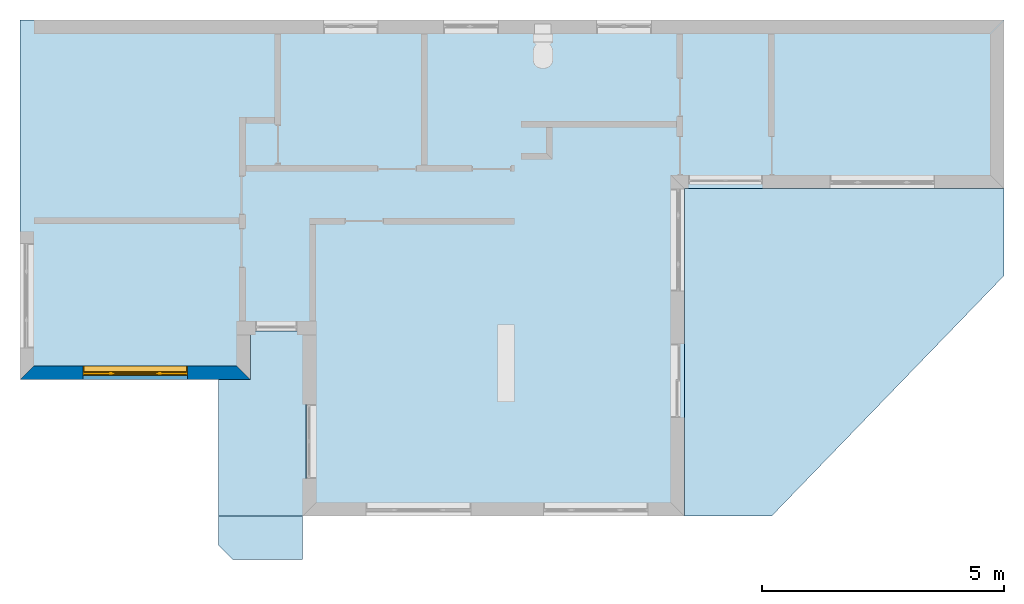
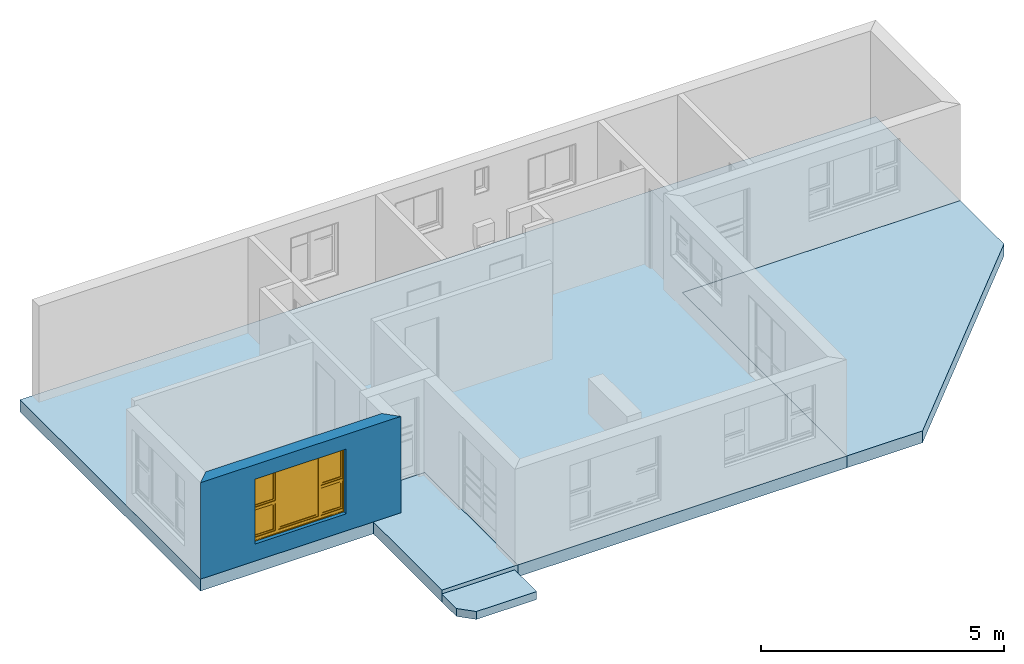
# One storey, part 1 of 15: 4 slabs, 1 wall, 1 window, 1 opening.
"""IFC4 building model written with IfcOpenShell, lengths in millimetres."""

from ifc_helpers import new_model, entity, si_unit, converted_unit, frame, origin_with_axes, origin_2d_with_axis, place, context, subcontext, project, spatial, line, indexed_curve, outline, extrude, clip, halfspace, polygons, source, transform, mapped, material, layer, layer_set, layer_usage, type_object, type_shapes, element, fill, save


model = new_model("IFC4")

# Units and contexts
model_context = context("Model", 3, precision=1e-05, world=origin_with_axes())
plan_context = context("Plan", 2, precision=1e-05, world=origin_2d_with_axis())
body_context = subcontext(model_context, "Body", "Model", "MODEL_VIEW")
ifc_project = project(units=[si_unit("VOLUMEUNIT", "CUBIC_METRE"), si_unit("LENGTHUNIT", "METRE", prefix="MILLI"), converted_unit("PLANEANGLEUNIT", "degree", entity("IfcReal", 0.0174532925199433), si_unit("PLANEANGLEUNIT", "RADIAN"), dimensions=[0, 0, 0, 0, 0, 0, 0]), si_unit("AREAUNIT", "SQUARE_METRE")], contexts=[model_context, plan_context])

# Site, building, storey
site_placement = place(None, origin_with_axes())
site = spatial("IfcSite", under=ifc_project, at=site_placement)
building_placement = place(site_placement, origin_with_axes())
building = spatial("IfcBuilding", under=site, at=building_placement, Name="Building")
storey_placement = place(building_placement, origin_with_axes())
storey = spatial("IfcBuildingStorey", under=building, at=storey_placement, Name="EXISTING")

# Slabs
ifc_material = material()
ifc_layer_1 = layer(ifc_material, 200.0)
ifc_layer_set_1 = layer_set([ifc_layer_1])
ifc_layer_usage_1 = layer_usage(ifc_layer_set_1, "AXIS3", "POSITIVE", 0.0)
slab_type_1 = type_object("IfcSlabType", Name="FLR150", PredefinedType="NOTDEFINED", material=ifc_layer_set_1)
slab_1_placement = place(storey_placement, frame((3859.45892333984, -5518.33152770996, -300.000011920929), z_axis=(0.0, 0.0, 1.0), x_axis=(1.0, 0.0, 0.0)))
element("IfcSlab", 1, at=slab_1_placement, inside=storey, type_object=slab_type_1, material=ifc_layer_usage_1, Name="Slab", context=body_context, shape_type="SweptSolid", body=[
    extrude(outline(indexed_curve([(0.0, 399.999976158142), (1734.66002941132, 99.9999642372131), (1734.66002941132, 1000.0), (0.0, 1000.0), (299.999952316284, 99.9999642372131)], segments=[line(4, 1), line(1, 5), line(5, 2), line(2, 3), line(3, 4)], self_intersect=False)), None, (0.0, 0.0, 1.0), 200.0),
])
ifc_layer_2 = layer(ifc_material, 300.0)
ifc_layer_set_2 = layer_set([ifc_layer_2])
ifc_layer_usage_2 = layer_usage(ifc_layer_set_2, "AXIS3", "POSITIVE", 0.0)
slab_type_2 = type_object("IfcSlabType", Name="FLR250", PredefinedType="NOTDEFINED", material=ifc_layer_set_2)
slab_2_placement = place(storey_placement, frame((-250.880241394043, -1663.33293914795, -299.999982118607), z_axis=(0.0, 0.0, 1.0), x_axis=(0.999999999999993, 1.19209282445353e-07, 0.0)))
element("IfcSlab", 2, at=slab_2_placement, inside=storey, type_object=slab_type_2, material=ifc_layer_usage_2, Name="Slab", context=body_context, shape_type="SweptSolid", body=[
    extrude(outline(indexed_curve([(20355.001449585, 3920.0005531311), (20355.001449585, 7410.00032424927), (-0.00152846132550621, 7410.00032424927), (-0.00152846132550621, -29.9993697553873), (4765.00082015991, -29.9993697553873), (4765.00082015991, 894.999623298645), (5844.99883651733, 894.99968290329), (5844.99883651733, -2855.00049591064), (13744.9998855591, -2855.00049591064), (13744.9998855591, 3920.0005531311)], segments=[line(3, 2), line(2, 1), line(1, 10), line(10, 9), line(9, 8), line(8, 7), line(7, 6), line(6, 5), line(5, 4), line(4, 3)], self_intersect=False)), None, (0.0, 0.0, 1.0), 300.0),
])
ifc_layer_usage_3 = layer_usage(ifc_layer_set_2, "AXIS3", "POSITIVE", 0.0)
slab_3_placement = place(storey_placement, frame((4279.73222732544, -2320.44172286987, -300.000011920929), z_axis=(0.0, 0.0, 1.0), x_axis=(1.0, 0.0, 0.0)))
element("IfcSlab", 3, at=slab_3_placement, inside=storey, type_object=slab_type_2, material=ifc_layer_usage_3, Name="Slab", context=body_context, shape_type="SweptSolid", body=[
    extrude(outline(indexed_curve([(-420.273423194885, -2197.88980484009), (-420.273303985596, 627.109289169312), (234.388470649719, 627.108812332153), (234.38823223114, 1637.10832595825), (1384.38808917999, 1637.10832595825), (1384.38808917999, -2197.88980484009)], segments=[line(4, 3), line(3, 2), line(2, 1), line(1, 6), line(6, 5), line(5, 4)], self_intersect=False)), None, (0.0, 0.0, 1.0), 300.0),
])
ifc_layer_usage_4 = layer_usage(ifc_layer_set_2, "AXIS3", "POSITIVE", 0.0)
slab_4_placement = place(storey_placement, frame((13494.119644165, -4518.33248138428, -300.000011920929), z_axis=(0.0, 0.0, 1.0), x_axis=(1.0, 0.0, 0.0)))
element("IfcSlab", 4, at=slab_4_placement, inside=storey, type_object=slab_type_2, material=ifc_layer_usage_4, Name="Slab", context=body_context, shape_type="SweptSolid", body=[
    extrude(outline(indexed_curve([(0.0, 0.0), (6610.0025177002, 4975.00038146973), (6610.0025177002, 6775.00057220459), (0.0, 6775.00057220459), (1799.99911785126, 0.0)], segments=[line(3, 2), line(2, 5), line(5, 1), line(1, 4), line(4, 3)], self_intersect=False)), None, (0.0, 0.0, 1.0), 300.0),
])

# Wall, opening, window
ifc_layer_3 = layer(ifc_material, 285.0, Name="brick")
ifc_layer_set_3 = layer_set([ifc_layer_3])
ifc_layer_usage_5 = layer_usage(ifc_layer_set_3, "AXIS2", "POSITIVE", 0.0)
wall_type = type_object("IfcWallType", Name="285mm Wall", PredefinedType="STANDARD", material=ifc_layer_set_3)
wall_placement = place(storey_placement, frame((-250.882148742676, -1693.33171844482, 0.0), z_axis=(0.0, 0.0, 1.0), x_axis=(0.999999999999972, -2.38418579101556e-07, 0.0)))
wall = element("IfcWall", 5, at=wall_placement, inside=storey, type_object=wall_type, material=ifc_layer_usage_5, Name="Wall", context=body_context, shape_type="Clipping", body=[
    clip(clip(extrude(outline(indexed_curve([(0.0, 0.0), (0.0, 285.0), (4765.00220059561, 285.0), (4765.00220059561, 0.0), (0.0, 0.0)], self_intersect=False)), origin_with_axes(), (0.0, 0.0, 1.0), 2425.00019073486), halfspace(frame((-1.64313007644523e-11, -3.62376795237651e-10, 0.0), z_axis=(-0.707106828689575, 0.707106828689575, 0.0), x_axis=(0.707106781186547, 0.707106781186547, 0.0)), False)), halfspace(frame((4765.00225067139, -1.48929757415317e-07, 0.0), z_axis=(0.707106828689575, 0.707106649875641, 0.0), x_axis=(0.707106691779569, -0.707106870593514, 0.0)), False)),
])
shared_shape_1 = source(origin_with_axes(), body_context, "Body", "SweptSolid", [
    extrude(outline(indexed_curve([(0.0, 0.0), (2165.00024414062, 0.0), (2165.00024414062, 1629.99987792969), (0.0, 1629.99987792969)], segments=[line(1, 2, 3, 4, 1)])), frame((-1.04308121251506e-07, -600.0, 0.0), z_axis=(0.0, -1.0, 0.0), x_axis=(1.0, 0.0, 0.0)), (0.0, 0.0, -1.0), 1200.0),
])
opening_placement = place(wall_placement, frame((3465.00044796222, 136.110692322316, 430.000007152557), z_axis=(0.0, 0.0, 1.0), x_axis=(-0.999999999999989, 1.50995802528071e-07, 0.0)))
opening = element("IfcOpeningElement", 6, at=opening_placement, cuts=wall, Name="Opening", PredefinedType="OPENING", context=body_context, shape_type="MappedRepresentation", body=[
    mapped(shared_shape_1, transform((0.0, 0.0, 0.0), x_axis=(1.0, 0.0, 0.0), y_axis=(0.0, 1.0, 0.0), z_axis=(0.0, 0.0, 1.0), scale=1.0)),
])
window_type = type_object("IfcWindowType", Name="Ex.2165x1630", PartitioningType="NOTDEFINED", PredefinedType="WINDOW")
shared_shape_2 = source(origin_with_axes(), body_context, "Body", "Tessellation", [
    polygons([(2165.00048828125, -148.88883972168, 0.0), (2165.00048828125, -148.88883972168, 19.9999198913574), (0.000134110436192714, -148.888961791992, 0.0), (0.000134110436192714, -148.888961791992, 19.9999198913574), (2165.00048828125, 51.1111831665039, 0.0), (2165.00048828125, 51.1111831665039, 19.9999198913574), (0.000134110436192714, 51.1110649108887, 0.0), (0.000134110436192714, 51.1110649108887, 19.9999198913574), (2165.00048828125, -148.88883972168, 1609.99975585938), (2165.00048828125, -148.88883972168, 1630.0), (0.000134110436192714, -148.888961791992, 1609.99975585938), (0.000134110436192714, -148.888961791992, 1630.0), (2165.00048828125, 51.1111831665039, 1609.99975585938), (2165.00048828125, 51.1111831665039, 1630.0), (0.000134110436192714, 51.1110649108887, 1609.99975585938), (0.000134110436192714, 51.1110649108887, 1630.0), (0.000134110436192714, -148.88883972168, 19.9999198913574), (20.0003528594971, -148.88883972168, 19.9999198913574), (0.000134110436192714, -148.888961791992, 1609.99975585938), (20.000114440918, -148.888961791992, 1609.99975585938), (0.000134110436192714, 51.1111831665039, 19.9999198913574), (20.000114440918, 51.1111831665039, 19.9999198913574), (-0.000104308121080976, 51.1110649108887, 1609.99975585938), (20.000114440918, 51.1110649108887, 1609.99975585938), (2145.00048828125, -148.88883972168, 19.9999198913574), (2165.00048828125, -148.88883972168, 19.9999198913574), (2145.0, -148.888961791992, 1609.99975585938), (2165.0, -148.888961791992, 1609.99975585938), (2145.00048828125, 51.1111831665039, 19.9999198913574), (2165.00048828125, 51.1111831665039, 19.9999198913574), (2145.0, 51.1110649108887, 1609.99975585938), (2165.0, 51.1110649108887, 1609.99975585938), (1554.99987792969, -28.8888530731201, 19.9999198913574), (1625.0, -28.8888530731201, 19.9999198913574), (1554.99938964844, -28.8888530731201, 1609.99975585938), (1624.99951171875, -28.8888530731201, 1609.99975585938), (1554.99987792969, 41.1110763549805, 19.9999198913574), (1625.0, 41.1110763549805, 19.9999198913574), (1554.99938964844, 41.1110763549805, 1609.99975585938), (1624.99951171875, 41.1110763549805, 1609.99975585938), (540.000061035156, -28.8888530731201, 19.9999198913574), (610.000244140625, -28.8888530731201, 19.9999198913574), (539.999816894531, -28.8888530731201, 1609.99975585938), (610.0, -28.8888530731201, 1609.99975585938), (540.000061035156, 41.1110763549805, 19.9999198913574), (610.000244140625, 41.1110763549805, 19.9999198913574), (539.999816894531, 41.1110763549805, 1609.99975585938), (610.0, 41.1110763549805, 1609.99975585938), (20.000114440918, -28.888973236084, 844.999328613281), (20.000114440918, -28.888973236084, 775.000122070312), (540.000061035156, -28.8888530731201, 845.000061035156), (540.000061035156, -28.8888530731201, 775.000793457031), (20.000114440918, 41.1110763549805, 844.999328613281), (20.000114440918, 41.1110763549805, 775.000122070312), (540.000061035156, 41.1110763549805, 845.000061035156), (540.000061035156, 41.1111946105957, 775.000793457031), (1625.0, -28.888973236084, 844.999328613281), (1625.0, -28.888973236084, 775.000122070312), (2145.0, -28.8888530731201, 845.000061035156), (2145.0, -28.8888530731201, 775.000793457031), (1625.0, 41.1110763549805, 844.999328613281), (1625.0, 41.1110763549805, 775.000122070312), (2145.0, 41.1110763549805, 845.000061035156), (2145.0, 41.1111946105957, 775.000793457031), (1625.0, -13.8889875411987, 1609.99951171875), (1625.0, -13.8889875411987, 1569.99987792969), (2145.0, -13.8888683319092, 1609.99975585938), (2145.0, -13.8888683319092, 1570.00061035156), (1625.0, 26.1110916137695, 1609.99951171875), (1625.0, 26.1110916137695, 1569.99987792969), (2145.0, 26.1110916137695, 1610.00024414062), (2145.0, 26.1110916137695, 1570.00061035156), (1625.0, -13.8889875411987, 884.9990234375), (1625.0, -13.8889875411987, 844.999328613281), (2145.0, -13.8888683319092, 884.99951171875), (2145.0, -13.8888683319092, 844.999938964844), (1625.0, 26.1110916137695, 884.9990234375), (1625.0, 26.1110916137695, 844.999328613281), (2145.0, 26.1110916137695, 884.99951171875), (2145.0, 26.1110916137695, 844.999938964844), (1665.0, -13.8888683319092, 1570.00012207031), (1625.0, -13.8888683319092, 1570.00012207031), (1664.99975585938, -13.8888683319092, 884.9990234375), (1625.0, -13.8888683319092, 884.9990234375), (1665.0, 26.1110916137695, 1570.00012207031), (1625.0, 26.1110916137695, 1570.00012207031), (1664.99975585938, 26.1110916137695, 884.9990234375), (1625.0, 26.1110916137695, 884.9990234375), (2144.99951171875, -13.8888683319092, 1570.00012207031), (2105.00024414062, -13.8888683319092, 1570.00012207031), (2144.99951171875, -13.8888683319092, 884.9990234375), (2104.99975585938, -13.8888683319092, 884.9990234375), (2144.99951171875, 26.1110916137695, 1570.00012207031), (2105.00024414062, 26.1110916137695, 1570.00012207031), (2144.99951171875, 26.1110916137695, 884.9990234375), (2104.99975585938, 26.1110916137695, 884.9990234375), (20.0003528594971, -13.8889875411987, 1609.99951171875), (20.0003528594971, -13.8889875411987, 1569.99987792969), (540.000305175781, -13.8888683319092, 1609.99975585938), (540.000305175781, -13.8888683319092, 1570.00061035156), (20.0003528594971, 26.1110916137695, 1609.99951171875), (20.0003528594971, 26.1110916137695, 1569.99987792969), (540.000305175781, 26.1110916137695, 1610.00024414062), (540.000305175781, 26.1110916137695, 1570.00061035156), (20.0003528594971, -13.8889875411987, 884.9990234375), (20.0003528594971, -13.8889875411987, 844.999328613281), (540.000305175781, -13.8888683319092, 884.99951171875), (540.000305175781, -13.8888683319092, 844.999938964844), (20.0003528594971, 26.1110916137695, 884.9990234375), (20.0003528594971, 26.1110916137695, 844.999328613281), (540.000305175781, 26.1110916137695, 884.99951171875), (540.000305175781, 26.1110916137695, 844.999938964844), (60.0003128051758, -13.8888683319092, 1570.00012207031), (20.0005912780762, -13.8888683319092, 1570.00012207031), (60.000072479248, -13.8888683319092, 884.9990234375), (20.0005912780762, -13.8888683319092, 884.9990234375), (60.0003128051758, 26.1110916137695, 1570.00012207031), (20.0005912780762, 26.1110916137695, 1570.00012207031), (60.000072479248, 26.1110916137695, 884.9990234375), (20.0005912780762, 26.1110916137695, 884.9990234375), (539.999572753906, -13.8888683319092, 1570.00012207031), (499.999847412109, -13.8888683319092, 1570.00012207031), (539.999572753906, -13.8888683319092, 884.9990234375), (499.999603271484, -13.8888683319092, 884.9990234375), (539.999572753906, 26.1110916137695, 1570.00012207031), (499.999847412109, 26.1110916137695, 1570.00012207031), (539.999572753906, 26.1110916137695, 884.9990234375), (499.999603271484, 26.1110916137695, 884.9990234375), (20.000114440918, -28.888973236084, 89.9992523193359), (20.000114440918, -28.888973236084, 19.9997406005859), (540.000061035156, -28.8888530731201, 89.9999694824219), (540.000061035156, -28.8888530731201, 20.0004558563232), (20.000114440918, 41.1110763549805, 89.9992523193359), (20.000114440918, 41.1110763549805, 19.9997406005859), (540.000061035156, 41.1110763549805, 89.9999694824219), (540.000061035156, 41.1111946105957, 20.0004558563232), (1625.0, -28.888973236084, 89.9992523193359), (1625.0, -28.888973236084, 19.9997406005859), (2145.0, -28.8888530731201, 89.9999694824219), (2145.0, -28.8888530731201, 20.0004558563232), (1625.0, 41.1110763549805, 89.9992523193359), (1625.0, 41.1110763549805, 19.9997406005859), (2145.0, 41.1110763549805, 89.9999694824219), (2145.0, 41.1111946105957, 20.0004558563232), (610.000244140625, -28.888973236084, 89.9992523193359), (610.000244140625, -28.888973236084, 19.9997406005859), (1554.99987792969, -28.8888530731201, 89.9999694824219), (1554.99987792969, -28.8888530731201, 20.0004558563232), (610.000244140625, 41.1110763549805, 89.9992523193359), (610.000244140625, 41.1110763549805, 19.9997406005859), (1554.99987792969, 41.1110763549805, 89.9999694824219), (1554.99987792969, 41.1110763549805, 20.0004558563232), (1625.0, -13.8889875411987, 775.000244140625), (1625.0, -13.8889875411987, 735.000366210938), (2145.0, -13.8888683319092, 775.000793457031), (2145.0, -13.8888683319092, 735.001098632812), (1625.0, 26.1110916137695, 775.000244140625), (1625.0, 26.1110916137695, 735.000366210938), (2145.0, 26.1110916137695, 775.000793457031), (2145.0, 26.1110916137695, 735.001098632812), (1625.0, -13.8889875411987, 129.999694824219), (1625.0, -13.8889875411987, 89.9999694824219), (2145.0, -13.8888683319092, 130.00016784668), (2145.0, -13.8888683319092, 90.0005645751953), (1625.0, 26.1110916137695, 129.999694824219), (1625.0, 26.1110916137695, 89.9999694824219), (2145.0, 26.1110916137695, 130.00016784668), (2145.0, 26.1110916137695, 90.0005645751953), (1665.0, -13.8888683319092, 735.000610351562), (1625.0, -13.8888683319092, 735.000610351562), (1664.99975585938, -13.8888683319092, 129.998977661133), (1625.0, -13.8888683319092, 129.999099731445), (1665.0, 26.1110916137695, 735.000610351562), (1625.0, 26.1110916137695, 735.000610351562), (1664.99975585938, 26.1110916137695, 129.998977661133), (1625.0, 26.1110916137695, 129.999099731445), (2144.99951171875, -13.8888683319092, 735.000610351562), (2105.00024414062, -13.8888683319092, 735.000610351562), (2144.99951171875, -13.8888683319092, 129.998977661133), (2104.99975585938, -13.8888683319092, 129.999099731445), (2144.99951171875, 26.1110916137695, 735.000610351562), (2105.00024414062, 26.1110916137695, 735.000610351562), (2144.99951171875, 26.1110916137695, 129.998977661133), (2104.99975585938, 26.1110916137695, 129.999099731445), (20.0003528594971, -13.8889875411987, 775.000244140625), (20.0003528594971, -13.8889875411987, 735.000366210938), (540.000305175781, -13.8888683319092, 775.000793457031), (540.000305175781, -13.8888683319092, 735.001098632812), (20.0003528594971, 26.1110916137695, 775.000244140625), (20.0003528594971, 26.1110916137695, 735.000366210938), (540.000305175781, 26.1110916137695, 775.000793457031), (540.000305175781, 26.1110916137695, 735.001098632812), (20.0003528594971, -13.8889875411987, 129.998611450195), (20.0003528594971, -13.8889875411987, 89.9989547729492), (540.000305175781, -13.8888683319092, 129.999099731445), (540.000305175781, -13.8888683319092, 89.9994354248047), (20.0003528594971, 26.1110916137695, 129.998611450195), (20.0003528594971, 26.1110916137695, 89.9989547729492), (540.000305175781, 26.1110916137695, 129.999206542969), (540.000305175781, 26.1110916137695, 89.9994354248047), (60.0003128051758, -13.8888683319092, 735.000610351562), (20.0005912780762, -13.8888683319092, 735.000610351562), (60.000072479248, -13.8888683319092, 129.998977661133), (20.0005912780762, -13.8888683319092, 129.999099731445), (60.0003128051758, 26.1110916137695, 735.000610351562), (20.0005912780762, 26.1110916137695, 735.000610351562), (60.000072479248, 26.1110916137695, 129.998977661133), (20.0005912780762, 26.1110916137695, 129.999099731445), (539.999572753906, -13.8888683319092, 735.000610351562), (499.999847412109, -13.8888683319092, 735.000610351562), (539.999572753906, -13.8888683319092, 129.998977661133), (499.999603271484, -13.8888683319092, 129.999099731445), (539.999572753906, 26.1110916137695, 735.000610351562), (499.999847412109, 26.1110916137695, 735.000610351562), (539.999572753906, 26.1110916137695, 129.998977661133), (499.999603271484, 26.1110916137695, 129.999099731445), (610.000427246094, -13.8889875411987, 1609.99951171875), (610.000427246094, -13.8889875411987, 1569.99987792969), (1554.99987792969, -13.8888683319092, 1609.99975585938), (1554.99987792969, -13.8888683319092, 1570.00061035156), (610.000427246094, 26.1110916137695, 1609.99951171875), (610.000427246094, 26.1110916137695, 1569.99987792969), (1554.99987792969, 26.1110916137695, 1610.00024414062), (1554.99987792969, 26.1110916137695, 1570.00061035156), (610.000427246094, -13.8889875411987, 129.998916625977), (610.000427246094, -13.8889875411987, 89.9992523193359), (1554.99987792969, -13.8888683319092, 129.999389648438), (1554.99987792969, -13.8888683319092, 89.9997863769531), (610.000427246094, 26.1110916137695, 129.998916625977), (610.000427246094, 26.1110916137695, 89.9992523193359), (1554.99987792969, 26.1110916137695, 129.999389648438), (1554.99987792969, 26.1110916137695, 89.9997863769531), (650.000183105469, -13.8888683319092, 1570.00012207031), (610.000671386719, -13.8888683319092, 1570.00012207031), (650.000183105469, -13.8888683319092, 129.999572753906), (610.000427246094, -13.8888683319092, 129.999572753906), (650.000183105469, 26.1110916137695, 1570.00012207031), (610.000671386719, 26.1110916137695, 1570.00012207031), (650.000183105469, 26.1110916137695, 129.999572753906), (610.000427246094, 26.1110916137695, 129.999572753906), (1554.99987792969, -13.8888683319092, 1570.00012207031), (1515.00012207031, -13.8888683319092, 1570.00012207031), (1554.99987792969, -13.8888683319092, 129.999389648438), (1515.00012207031, -13.8888683319092, 129.999389648438), (1554.99987792969, 26.1110916137695, 1570.00012207031), (1515.00012207031, 26.1110916137695, 1570.00012207031), (1554.99987792969, 26.1110916137695, 129.999389648438), (1515.00012207031, 26.1110916137695, 129.999389648438), (1515.00012207031, 1.11111617088318, 1570.00012207031), (650.001586914062, 1.11111617088318, 1570.00012207031), (1515.00012207031, 1.11111617088318, 129.999450683594), (650.001342773438, 1.11111617088318, 129.999572753906), (1515.00012207031, 11.1111059188843, 1570.00012207031), (650.001586914062, 11.1111059188843, 1570.00012207031), (1515.00012207031, 11.1111059188843, 129.999450683594), (650.001342773438, 11.1111059188843, 129.999572753906), (2104.99877929688, 1.11111617088318, 1570.00012207031), (1665.0, 1.11111617088318, 1570.00012207031), (2104.99877929688, 1.11111617088318, 884.99951171875), (1664.99975585938, 1.11111617088318, 884.99951171875), (2104.99877929688, 11.1111059188843, 1570.00012207031), (1665.0, 11.1111059188843, 1570.00012207031), (2104.99877929688, 11.1111059188843, 884.99951171875), (1664.99975585938, 11.1111059188843, 884.99951171875), (2104.99877929688, 1.11111617088318, 735.000366210938), (1665.0, 1.11111617088318, 735.000610351562), (2104.99877929688, 1.11111617088318, 130.000518798828), (1664.99975585938, 1.11111617088318, 130.000518798828), (2104.99877929688, 11.1111059188843, 735.000366210938), (1665.0, 11.1111059188843, 735.000610351562), (2104.99877929688, 11.1111059188843, 130.000518798828), (1664.99975585938, 11.1111059188843, 130.000518798828), (499.998901367188, 1.11111617088318, 1570.00012207031), (60.0003128051758, 1.11111617088318, 1570.00012207031), (499.998657226562, 1.11111617088318, 884.99951171875), (60.000072479248, 1.11111617088318, 884.99951171875), (499.998901367188, 11.1111059188843, 1570.00012207031), (60.0003128051758, 11.1111059188843, 1570.00012207031), (499.998657226562, 11.1111059188843, 884.99951171875), (60.000072479248, 11.1111059188843, 884.99951171875), (499.998901367188, 1.11111617088318, 735.000366210938), (60.0003128051758, 1.11111617088318, 735.000610351562), (499.998657226562, 1.11111617088318, 130.000518798828), (60.000072479248, 1.11111617088318, 130.000518798828), (499.998901367188, 11.1111059188843, 735.000366210938), (60.0003128051758, 11.1111059188843, 735.000610351562), (499.998657226562, 11.1111059188843, 130.000518798828), (60.000072479248, 11.1111059188843, 130.000518798828)], [[[1, 2, 4, 3]], [[3, 4, 8, 7]], [[7, 8, 6, 5]], [[5, 6, 2, 1]], [[3, 7, 5, 1]], [[8, 4, 2, 6]], [[9, 10, 12, 11]], [[11, 12, 16, 15]], [[15, 16, 14, 13]], [[13, 14, 10, 9]], [[11, 15, 13, 9]], [[16, 12, 10, 14]], [[17, 18, 20, 19]], [[19, 20, 24, 23]], [[23, 24, 22, 21]], [[21, 22, 18, 17]], [[19, 23, 21, 17]], [[24, 20, 18, 22]], [[25, 26, 28, 27]], [[27, 28, 32, 31]], [[31, 32, 30, 29]], [[29, 30, 26, 25]], [[27, 31, 29, 25]], [[32, 28, 26, 30]], [[33, 34, 36, 35]], [[35, 36, 40, 39]], [[39, 40, 38, 37]], [[37, 38, 34, 33]], [[35, 39, 37, 33]], [[40, 36, 34, 38]], [[41, 42, 44, 43]], [[43, 44, 48, 47]], [[47, 48, 46, 45]], [[45, 46, 42, 41]], [[43, 47, 45, 41]], [[48, 44, 42, 46]], [[49, 50, 52, 51]], [[51, 52, 56, 55]], [[55, 56, 54, 53]], [[53, 54, 50, 49]], [[51, 55, 53, 49]], [[56, 52, 50, 54]], [[57, 58, 60, 59]], [[59, 60, 64, 63]], [[63, 64, 62, 61]], [[61, 62, 58, 57]], [[59, 63, 61, 57]], [[64, 60, 58, 62]], [[65, 66, 68, 67]], [[67, 68, 72, 71]], [[71, 72, 70, 69]], [[69, 70, 66, 65]], [[67, 71, 69, 65]], [[72, 68, 66, 70]], [[73, 74, 76, 75]], [[75, 76, 80, 79]], [[79, 80, 78, 77]], [[77, 78, 74, 73]], [[75, 79, 77, 73]], [[80, 76, 74, 78]], [[81, 82, 84, 83]], [[83, 84, 88, 87]], [[87, 88, 86, 85]], [[85, 86, 82, 81]], [[83, 87, 85, 81]], [[88, 84, 82, 86]], [[89, 90, 92, 91]], [[91, 92, 96, 95]], [[95, 96, 94, 93]], [[93, 94, 90, 89]], [[91, 95, 93, 89]], [[96, 92, 90, 94]], [[97, 98, 100, 99]], [[99, 100, 104, 103]], [[103, 104, 102, 101]], [[101, 102, 98, 97]], [[99, 103, 101, 97]], [[104, 100, 98, 102]], [[105, 106, 108, 107]], [[107, 108, 112, 111]], [[111, 112, 110, 109]], [[109, 110, 106, 105]], [[107, 111, 109, 105]], [[112, 108, 106, 110]], [[113, 114, 116, 115]], [[115, 116, 120, 119]], [[119, 120, 118, 117]], [[117, 118, 114, 113]], [[115, 119, 117, 113]], [[120, 116, 114, 118]], [[121, 122, 124, 123]], [[123, 124, 128, 127]], [[127, 128, 126, 125]], [[125, 126, 122, 121]], [[123, 127, 125, 121]], [[128, 124, 122, 126]], [[129, 130, 132, 131]], [[131, 132, 136, 135]], [[135, 136, 134, 133]], [[133, 134, 130, 129]], [[131, 135, 133, 129]], [[136, 132, 130, 134]], [[137, 138, 140, 139]], [[139, 140, 144, 143]], [[143, 144, 142, 141]], [[141, 142, 138, 137]], [[139, 143, 141, 137]], [[144, 140, 138, 142]], [[145, 146, 148, 147]], [[147, 148, 152, 151]], [[151, 152, 150, 149]], [[149, 150, 146, 145]], [[147, 151, 149, 145]], [[152, 148, 146, 150]], [[153, 154, 156, 155]], [[155, 156, 160, 159]], [[159, 160, 158, 157]], [[157, 158, 154, 153]], [[155, 159, 157, 153]], [[160, 156, 154, 158]], [[161, 162, 164, 163]], [[163, 164, 168, 167]], [[167, 168, 166, 165]], [[165, 166, 162, 161]], [[163, 167, 165, 161]], [[168, 164, 162, 166]], [[169, 170, 172, 171]], [[171, 172, 176, 175]], [[175, 176, 174, 173]], [[173, 174, 170, 169]], [[171, 175, 173, 169]], [[176, 172, 170, 174]], [[177, 178, 180, 179]], [[179, 180, 184, 183]], [[183, 184, 182, 181]], [[181, 182, 178, 177]], [[179, 183, 181, 177]], [[184, 180, 178, 182]], [[185, 186, 188, 187]], [[187, 188, 192, 191]], [[191, 192, 190, 189]], [[189, 190, 186, 185]], [[187, 191, 189, 185]], [[192, 188, 186, 190]], [[193, 194, 196, 195]], [[195, 196, 200, 199]], [[199, 200, 198, 197]], [[197, 198, 194, 193]], [[195, 199, 197, 193]], [[200, 196, 194, 198]], [[201, 202, 204, 203]], [[203, 204, 208, 207]], [[207, 208, 206, 205]], [[205, 206, 202, 201]], [[203, 207, 205, 201]], [[208, 204, 202, 206]], [[209, 210, 212, 211]], [[211, 212, 216, 215]], [[215, 216, 214, 213]], [[213, 214, 210, 209]], [[211, 215, 213, 209]], [[216, 212, 210, 214]], [[217, 218, 220, 219]], [[219, 220, 224, 223]], [[223, 224, 222, 221]], [[221, 222, 218, 217]], [[219, 223, 221, 217]], [[224, 220, 218, 222]], [[225, 226, 228, 227]], [[227, 228, 232, 231]], [[231, 232, 230, 229]], [[229, 230, 226, 225]], [[227, 231, 229, 225]], [[232, 228, 226, 230]], [[233, 234, 236, 235]], [[235, 236, 240, 239]], [[239, 240, 238, 237]], [[237, 238, 234, 233]], [[235, 239, 237, 233]], [[240, 236, 234, 238]], [[241, 242, 244, 243]], [[243, 244, 248, 247]], [[247, 248, 246, 245]], [[245, 246, 242, 241]], [[243, 247, 245, 241]], [[248, 244, 242, 246]], [[249, 250, 252, 251]], [[251, 252, 256, 255]], [[255, 256, 254, 253]], [[253, 254, 250, 249]], [[251, 255, 253, 249]], [[256, 252, 250, 254]], [[257, 258, 260, 259]], [[259, 260, 264, 263]], [[263, 264, 262, 261]], [[261, 262, 258, 257]], [[259, 263, 261, 257]], [[264, 260, 258, 262]], [[265, 266, 268, 267]], [[267, 268, 272, 271]], [[271, 272, 270, 269]], [[269, 270, 266, 265]], [[267, 271, 269, 265]], [[272, 268, 266, 270]], [[273, 274, 276, 275]], [[275, 276, 280, 279]], [[279, 280, 278, 277]], [[277, 278, 274, 273]], [[275, 279, 277, 273]], [[280, 276, 274, 278]], [[281, 282, 284, 283]], [[283, 284, 288, 287]], [[287, 288, 286, 285]], [[285, 286, 282, 281]], [[283, 287, 285, 281]], [[288, 284, 282, 286]]], closed=True),
])
type_shapes(window_type, [shared_shape_2])
window_placement = place(opening_placement, frame((-0.000149011438299596, -0.000439584362244005, 3.88578058618805e-13), z_axis=(0.0, 0.0, 1.0), x_axis=(1.0, 1.42108547681416e-14, 0.0)))
window = element("IfcWindow", 7, at=window_placement, inside=storey, type_object=window_type, Name="Window", context=body_context, shape_type="MappedRepresentation", body=[
    mapped(shared_shape_2, transform((0.0, 0.0, 0.0), x_axis=(1.0, 0.0, 0.0), y_axis=(0.0, 1.0, 0.0), z_axis=(0.0, 0.0, 1.0), scale=1.0)),
])
fill(opening, window)

save(model, "model.ifc")
